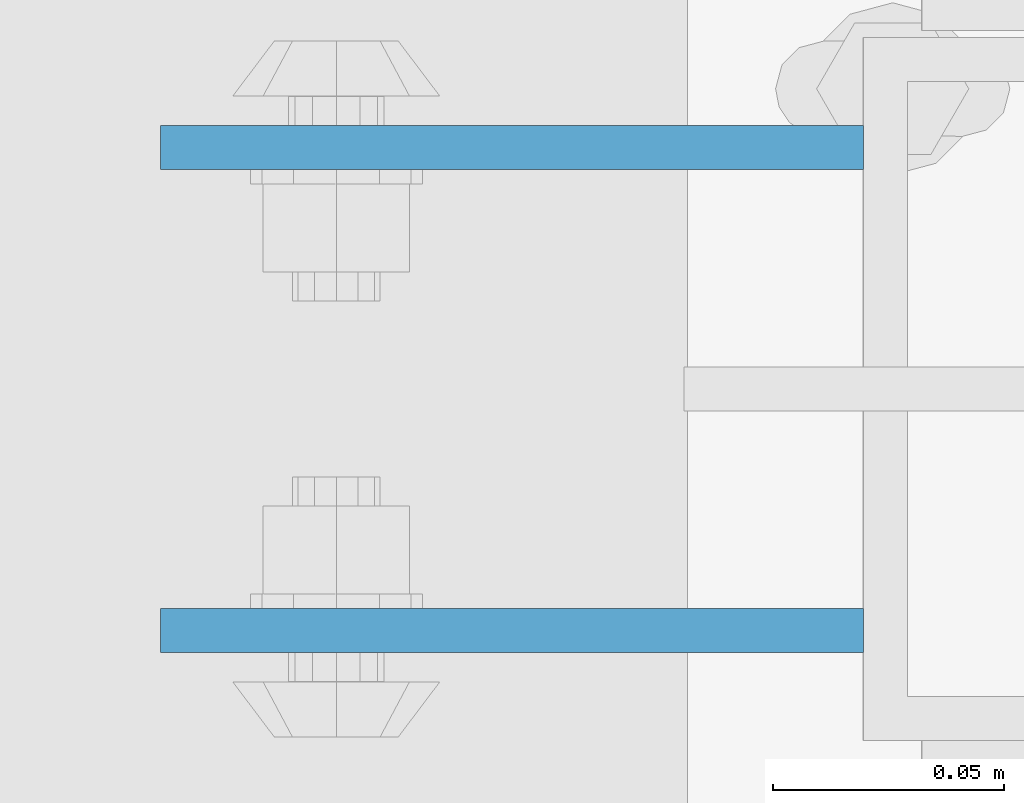
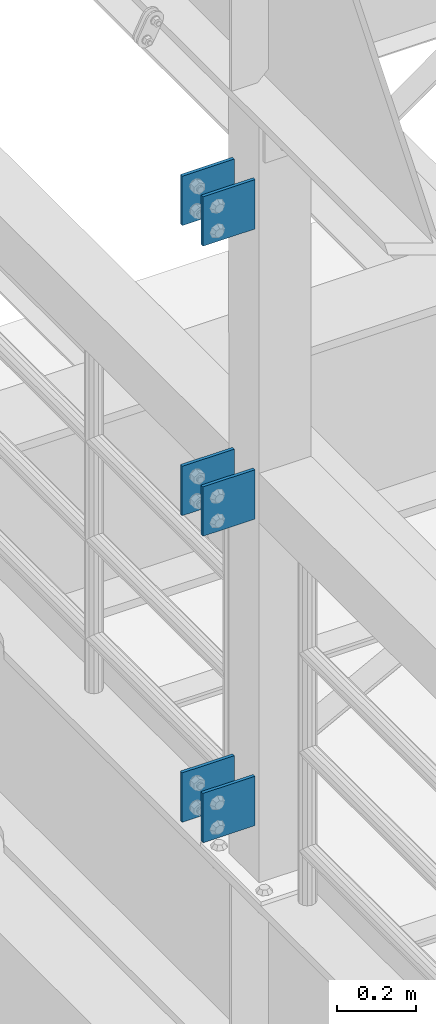
# One storey, part 1256 of 1876: 6 beams, 1 element without a shape of its own.
"""IFC2X3 building model written with IfcOpenShell, lengths in millimetres."""

from ifc_helpers import new_model, si_unit, frame, origin_with_axes, place, context, subcontext, project, spatial, faceted_brep, material, type_object, element, aggregate, save


model = new_model("IFC2X3")

# Units and contexts
model_context = context("Model", 3, precision=1e-05, world=origin_with_axes())
body_context = subcontext(model_context, "Body", "Model", "MODEL_VIEW")
ifc_project = project(units=[si_unit("LENGTHUNIT", "METRE", prefix="MILLI"), si_unit("AREAUNIT", "SQUARE_METRE"), si_unit("VOLUMEUNIT", "CUBIC_METRE"), si_unit("MASSUNIT", "GRAM", prefix="KILO"), si_unit("TIMEUNIT", "SECOND"), si_unit("PLANEANGLEUNIT", "RADIAN"), si_unit("SOLIDANGLEUNIT", "STERADIAN"), si_unit("THERMODYNAMICTEMPERATUREUNIT", "DEGREE_CELSIUS"), si_unit("LUMINOUSINTENSITYUNIT", "LUMEN")], contexts=[model_context])

# Site, building, storey
site_placement = place(None, origin_with_axes())
site = spatial("IfcSite", under=ifc_project, at=site_placement, CompositionType="ELEMENT")
building_placement = place(site_placement, origin_with_axes())
building = spatial("IfcBuilding", under=site, at=building_placement, Name="Undefined", CompositionType="ELEMENT")
storey_placement = place(building_placement, origin_with_axes())
storey = spatial("IfcBuildingStorey", under=building, at=storey_placement, Name="Undefined", CompositionType="ELEMENT", Elevation=0.0)

# Assembly, beams
assembly_placement = place(storey_placement, origin_with_axes())
assembly = element("IfcElementAssembly", 1, at=assembly_placement, inside=storey, Name="BEAM", AssemblyPlace="NOTDEFINED", PredefinedType="RIGID_FRAME")
ifc_material = material(Name="STEEL/A36")
beam_type = type_object("IfcBeamType", PredefinedType="NOTDEFINED")
beam_1_placement = place(assembly_placement, frame((-76.2, 5640.3875, 6330.95), z_axis=(0.0, 0.0, -1.0), x_axis=(-1.0, 0.0, 0.0)))
beam_1 = element("IfcBeam", 2, at=beam_1_placement, type_object=beam_type, material=ifc_material, Name="PLATE", context=body_context, shape_type="Brep", body=[
    faceted_brep([(0.0, 4.76249999999982, -76.1999999999998), (3.63797880709171e-12, 4.76249999999982, 76.1999969482422), (152.399993896484, 4.76250000000073, 76.1999969482422), (152.4, 4.76249999999982, -76.1999999999998), (3.63797880709171e-12, -4.76249999999982, 76.1999969482422), (152.399993896484, -4.76250000000073, 76.1999969482422), (0.0, -4.76249999999982, -76.1999999999998), (152.4, -4.76249999999982, -76.1999999999998)], [[[0, 1, 2, 3]], [[4, 5, 2, 1]], [[4, 6, 7, 5]], [[6, 0, 3, 7]], [[5, 7, 3, 2]], [[6, 4, 1, 0]]]),
])
beam_2_placement = place(assembly_placement, frame((-76.2, 5535.6125, 6330.95), z_axis=(0.0, 0.0, -1.0), x_axis=(-1.0, 0.0, 0.0)))
beam_2 = element("IfcBeam", 3, at=beam_2_placement, type_object=beam_type, material=ifc_material, Name="PLATE", context=body_context, shape_type="Brep", body=[
    faceted_brep([(0.0, 4.76249999999982, -76.1999999999998), (3.63797880709171e-12, 4.76249999999982, 76.1999969482422), (152.399993896484, 4.76250000000073, 76.1999969482422), (152.4, 4.76249999999982, -76.1999999999998), (3.63797880709171e-12, -4.76249999999982, 76.1999969482422), (152.399993896484, -4.76250000000073, 76.1999969482422), (0.0, -4.76249999999982, -76.1999999999998), (152.4, -4.76249999999982, -76.1999999999998)], [[[0, 1, 2, 3]], [[4, 5, 2, 1]], [[4, 6, 7, 5]], [[6, 0, 3, 7]], [[5, 7, 3, 2]], [[6, 4, 1, 0]]]),
])
beam_3_placement = place(assembly_placement, frame((-76.2, 5640.3875, 7226.3), z_axis=(0.0, 0.0, -1.0), x_axis=(-1.0, 0.0, 0.0)))
beam_3 = element("IfcBeam", 4, at=beam_3_placement, type_object=beam_type, material=ifc_material, Name="PLATE", context=body_context, shape_type="Brep", body=[
    faceted_brep([(0.0, 4.76249999999982, -76.1999999999998), (3.63797880709171e-12, 4.76249999999982, 76.1999969482422), (152.399993896484, 4.76250000000073, 76.1999969482422), (152.4, 4.76249999999982, -76.1999999999998), (3.63797880709171e-12, -4.76249999999982, 76.1999969482422), (152.399993896484, -4.76250000000073, 76.1999969482422), (0.0, -4.76249999999982, -76.1999999999998), (152.4, -4.76249999999982, -76.1999999999998)], [[[0, 1, 2, 3]], [[4, 5, 2, 1]], [[4, 6, 7, 5]], [[6, 0, 3, 7]], [[5, 7, 3, 2]], [[6, 4, 1, 0]]]),
])
beam_4_placement = place(assembly_placement, frame((-76.2, 5535.6125, 7226.3), z_axis=(0.0, 0.0, -1.0), x_axis=(-1.0, 0.0, 0.0)))
beam_4 = element("IfcBeam", 5, at=beam_4_placement, type_object=beam_type, material=ifc_material, Name="PLATE", context=body_context, shape_type="Brep", body=[
    faceted_brep([(0.0, 4.76249999999982, -76.1999999999998), (3.63797880709171e-12, 4.76249999999982, 76.1999969482422), (152.399993896484, 4.76250000000073, 76.1999969482422), (152.4, 4.76249999999982, -76.1999999999998), (3.63797880709171e-12, -4.76249999999982, 76.1999969482422), (152.399993896484, -4.76250000000073, 76.1999969482422), (0.0, -4.76249999999982, -76.1999999999998), (152.4, -4.76249999999982, -76.1999999999998)], [[[0, 1, 2, 3]], [[4, 5, 2, 1]], [[4, 6, 7, 5]], [[6, 0, 3, 7]], [[5, 7, 3, 2]], [[6, 4, 1, 0]]]),
])
beam_5_placement = place(assembly_placement, frame((-76.2, 5640.3875, 5384.8), z_axis=(0.0, 0.0, -1.0), x_axis=(-1.0, 0.0, 0.0)))
beam_5 = element("IfcBeam", 6, at=beam_5_placement, type_object=beam_type, material=ifc_material, Name="PLATE", context=body_context, shape_type="Brep", body=[
    faceted_brep([(0.0, 4.76249999999982, -76.1999999999998), (3.63797880709171e-12, 4.76249999999982, 76.1999969482422), (152.399993896484, 4.76250000000073, 76.1999969482422), (152.4, 4.76249999999982, -76.1999999999998), (3.63797880709171e-12, -4.76249999999982, 76.1999969482422), (152.399993896484, -4.76250000000073, 76.1999969482422), (0.0, -4.76249999999982, -76.1999999999998), (152.4, -4.76249999999982, -76.1999999999998)], [[[0, 1, 2, 3]], [[4, 5, 2, 1]], [[4, 6, 7, 5]], [[6, 0, 3, 7]], [[5, 7, 3, 2]], [[6, 4, 1, 0]]]),
])
beam_6_placement = place(assembly_placement, frame((-76.2, 5535.6125, 5384.8), z_axis=(0.0, 0.0, -1.0), x_axis=(-1.0, 0.0, 0.0)))
beam_6 = element("IfcBeam", 7, at=beam_6_placement, type_object=beam_type, material=ifc_material, Name="PLATE", context=body_context, shape_type="Brep", body=[
    faceted_brep([(0.0, 4.76249999999982, -76.1999999999998), (3.63797880709171e-12, 4.76249999999982, 76.1999969482422), (152.399993896484, 4.76250000000073, 76.1999969482422), (152.4, 4.76249999999982, -76.1999999999998), (3.63797880709171e-12, -4.76249999999982, 76.1999969482422), (152.399993896484, -4.76250000000073, 76.1999969482422), (0.0, -4.76249999999982, -76.1999999999998), (152.4, -4.76249999999982, -76.1999999999998)], [[[0, 1, 2, 3]], [[4, 5, 2, 1]], [[4, 6, 7, 5]], [[6, 0, 3, 7]], [[5, 7, 3, 2]], [[6, 4, 1, 0]]]),
])
aggregate(assembly, [beam_1, beam_2, beam_3, beam_4, beam_5, beam_6])

save(model, "model.ifc")
